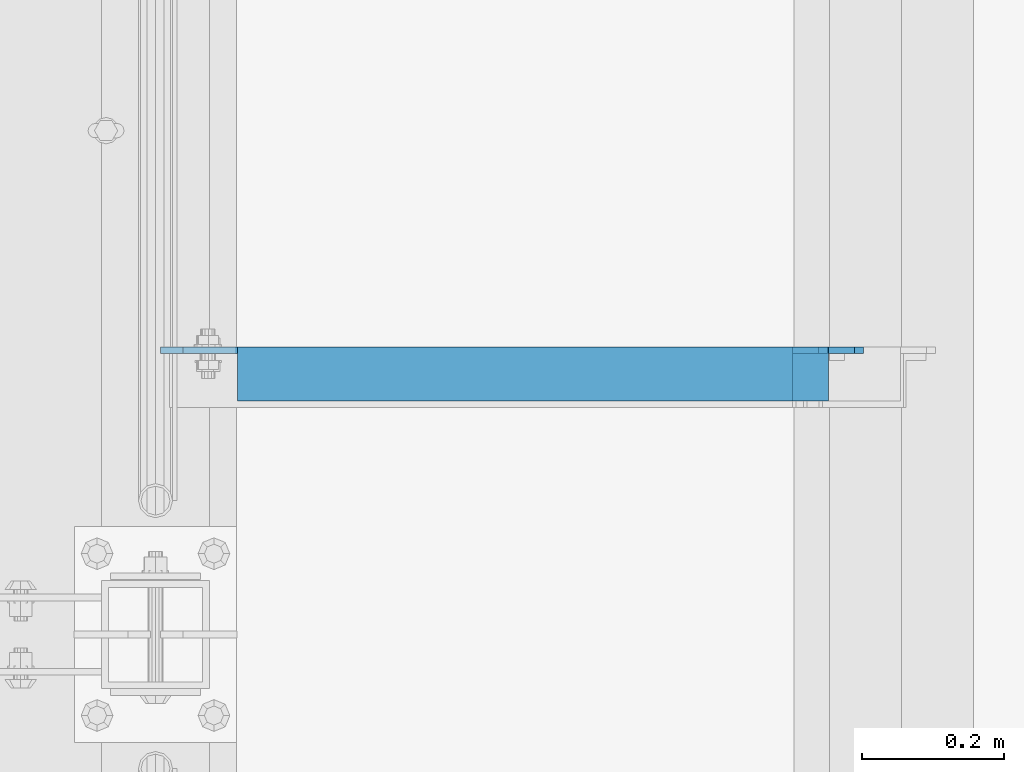
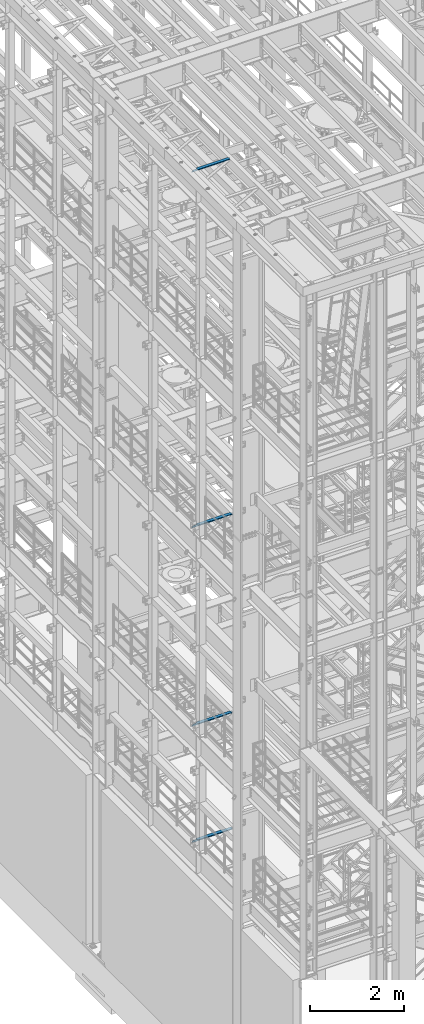
# One storey, part 1183 of 1876: 4 beams, 4 elements without a shape of their own.
"""IFC2X3 building model written with IfcOpenShell, lengths in millimetres."""

from ifc_helpers import new_model, si_unit, frame, origin_with_axes, place, context, subcontext, project, spatial, faceted_brep, material, type_object, element, aggregate, save


model = new_model("IFC2X3")

# Units and contexts
model_context = context("Model", 3, precision=1e-05, world=origin_with_axes())
body_context = subcontext(model_context, "Body", "Model", "MODEL_VIEW")
ifc_project = project(units=[si_unit("LENGTHUNIT", "METRE", prefix="MILLI"), si_unit("AREAUNIT", "SQUARE_METRE"), si_unit("VOLUMEUNIT", "CUBIC_METRE"), si_unit("MASSUNIT", "GRAM", prefix="KILO"), si_unit("TIMEUNIT", "SECOND"), si_unit("PLANEANGLEUNIT", "RADIAN"), si_unit("SOLIDANGLEUNIT", "STERADIAN"), si_unit("THERMODYNAMICTEMPERATUREUNIT", "DEGREE_CELSIUS"), si_unit("LUMINOUSINTENSITYUNIT", "LUMEN")], contexts=[model_context])

# Site, building, storey
site_placement = place(None, origin_with_axes())
site = spatial("IfcSite", under=ifc_project, at=site_placement, CompositionType="ELEMENT")
building_placement = place(site_placement, origin_with_axes())
building = spatial("IfcBuilding", under=site, at=building_placement, Name="Undefined", CompositionType="ELEMENT")
storey_placement = place(building_placement, origin_with_axes())
storey = spatial("IfcBuildingStorey", under=building, at=storey_placement, Name="Undefined", CompositionType="ELEMENT", Elevation=0.0)

# Assembly, beam
assembly_1_placement = place(storey_placement, origin_with_axes())
assembly_1 = element("IfcElementAssembly", 1, at=assembly_1_placement, inside=storey, Name="ANGLE", AssemblyPlace="NOTDEFINED", PredefinedType="RIGID_FRAME")
ifc_material = material(Name="STEEL/A36")
beam_type = type_object("IfcBeamType", Name="L3X3X3/8", PredefinedType="NOTDEFINED")
beam_1_placement = place(assembly_1_placement, frame((4.51516825708356e-09, -2171.7, 22517.1), z_axis=(0.0, -1.0, 0.0), x_axis=(1.0, 0.0, 0.0)))
beam_1 = element("IfcBeam", 2, at=beam_1_placement, type_object=beam_type, material=ifc_material, Name="ANGLE", ObjectType="L3X3X3/8", context=body_context, shape_type="Brep", body=[
    faceted_brep([(115.886999817316, 28.5750000000007, 38.0999999999999), (115.886999817316, 38.0999999999985, 38.0999999999999), (115.886998826692, 38.0999999999985, -38.0999999999999), (115.88699882669, 12.699999237062, -38.0999999999999), (115.886998950515, 12.699999237062, -28.5749999999998), (115.88699895052, 28.5750000000007, -28.5749999999998), (38.8937432114558, 12.699999237062, -38.0999999999999), (38.8937433352807, 12.699999237062, -28.5749999999998), (7.14374321145577, -19.050000762938, -38.0999999999999), (7.14374333528067, -19.050000762938, -28.5749999999998), (7.1437499954859, -38.0999999999985, -38.0999999999999), (7.1437499954859, -38.0999999999985, -28.5749999999998), (949.325002419604, 15.8750003814712, -28.5749999999998), (936.625002610339, 28.5750000000007, -28.5749999999998), (900.113000619098, 28.5750000000007, -28.5749999999998), (949.324999995485, -38.0999999999985, -28.5749999999998), (949.325002419604, 3.17500152588036, -28.5749999999998), (900.11300241932, 28.5750000000007, 38.0999999999999), (900.1130024193, 38.0999999999985, 38.0999999999999), (900.113000361957, 38.0999999999985, -38.0999999999999), (900.113000361924, 28.5750001907363, -38.0999999999999), (936.625002353164, 28.5750001907363, -38.0999999999999), (949.325002162429, 15.8750003814712, -38.0999999999999), (949.325002162429, 3.17500152588036, -38.0999999999999), (949.324999995485, -38.0999999999985, -38.0999999999999)], [[[0, 1, 2, 3, 4, 5]], [[4, 3, 6, 7]], [[7, 6, 8, 9]], [[8, 10, 11, 9]], [[12, 13, 14, 5, 4, 7, 9, 11, 15, 16]], [[0, 5, 14, 17]], [[1, 0, 17, 18]], [[2, 1, 18, 19]], [[17, 14, 20, 19, 18]], [[13, 21, 20, 14]], [[12, 22, 21, 13]], [[16, 23, 22, 12]], [[10, 8, 6, 3, 2, 19, 20, 21, 22, 23, 24]], [[11, 10, 24, 15]], [[23, 16, 15, 24]]]),
])
aggregate(assembly_1, [beam_1])

assembly_2_placement = place(storey_placement, origin_with_axes())
assembly_2 = element("IfcElementAssembly", 3, at=assembly_2_placement, inside=storey, Name="ANGLE", AssemblyPlace="NOTDEFINED", PredefinedType="RIGID_FRAME")
beam_2_placement = place(assembly_2_placement, frame((0.0, -2171.7, 8115.3), z_axis=(0.0, -1.0, 0.0), x_axis=(1.0, 0.0, 0.0)))
beam_2 = element("IfcBeam", 4, at=beam_2_placement, type_object=beam_type, material=ifc_material, Name="ANGLE", ObjectType="L3X3X3/8", context=body_context, shape_type="Brep", body=[
    faceted_brep([(115.886999817316, 28.5750000000007, 38.0999999999999), (115.886999817316, 38.0999999999985, 38.0999999999999), (115.886998826692, 38.0999999999985, -38.0999999999999), (115.88699882669, 12.699999237062, -38.0999999999999), (115.886998950515, 12.699999237062, -28.5749999999998), (115.88699895052, 28.5750000000007, -28.5749999999998), (38.8937432114558, 12.699999237062, -38.0999999999999), (38.8937433352807, 12.699999237062, -28.5749999999998), (7.14374321145577, -19.050000762938, -38.0999999999999), (7.14374333528067, -19.050000762938, -28.5749999999998), (7.1437499954859, -38.0999999999985, -38.0999999999999), (7.1437499954859, -38.0999999999985, -28.5749999999998), (1000.12500242412, 15.8750003814712, -28.5749999999998), (987.425002614851, 28.5749999999998, -28.5749999999998), (950.913000303442, 28.5749999999998, -28.5749999999998), (1000.12500001551, -38.1000000000004, -28.5749999999998), (1000.12500242412, 3.17500152588036, -28.5749999999998), (950.913001170238, 28.5749999999998, 38.0999999999999), (950.913001170238, 38.1000000000004, 38.0999999999999), (950.913000179614, 38.1000000000004, -38.0999999999999), (950.913000366403, 28.5750001907363, -38.0999999999999), (987.425002357675, 28.5750001907363, -38.0999999999999), (1000.12500216694, 15.8750003814712, -38.0999999999999), (1000.12500216694, 3.17500152588036, -38.0999999999999), (1000.12500001551, -38.1000000000004, -38.0999999999999)], [[[0, 1, 2, 3, 4, 5]], [[4, 3, 6, 7]], [[7, 6, 8, 9]], [[8, 10, 11, 9]], [[12, 13, 14, 5, 4, 7, 9, 11, 15, 16]], [[0, 5, 14, 17]], [[1, 0, 17, 18]], [[2, 1, 18, 19]], [[17, 14, 20, 19, 18]], [[13, 21, 20, 14]], [[12, 22, 21, 13]], [[16, 23, 22, 12]], [[10, 8, 6, 3, 2, 19, 20, 21, 22, 23, 24]], [[11, 10, 24, 15]], [[23, 16, 15, 24]]]),
])
aggregate(assembly_2, [beam_2])

assembly_3_placement = place(storey_placement, origin_with_axes())
assembly_3 = element("IfcElementAssembly", 5, at=assembly_3_placement, inside=storey, Name="ANGLE", AssemblyPlace="NOTDEFINED", PredefinedType="RIGID_FRAME")
beam_3_placement = place(assembly_3_placement, frame((0.0, -2171.7, 5092.7), z_axis=(0.0, -1.0, 0.0), x_axis=(1.0, 0.0, 0.0)))
beam_3 = element("IfcBeam", 6, at=beam_3_placement, type_object=beam_type, material=ifc_material, Name="ANGLE", ObjectType="L3X3X3/8", context=body_context, shape_type="Brep", body=[
    faceted_brep([(115.886999817316, 28.5750000000007, 38.0999999999999), (115.886999817316, 38.0999999999985, 38.0999999999999), (115.886998826692, 38.0999999999985, -38.0999999999999), (115.88699882669, 12.699999237062, -38.0999999999999), (115.886998950515, 12.699999237062, -28.5749999999998), (115.88699895052, 28.5750000000007, -28.5749999999998), (38.8937432114558, 12.699999237062, -38.0999999999999), (38.8937433352807, 12.699999237062, -28.5749999999998), (7.14374321145577, -19.050000762938, -38.0999999999999), (7.14374333528067, -19.050000762938, -28.5749999999998), (7.1437499954859, -38.0999999999985, -38.0999999999999), (7.1437499954859, -38.0999999999985, -28.5749999999998), (1000.12500242412, 15.8750003814712, -28.5749999999998), (987.425002614851, 28.5749999999998, -28.5749999999998), (950.913000303442, 28.5749999999998, -28.5749999999998), (1000.12500001551, -38.1000000000004, -28.5749999999998), (1000.12500242412, 3.17500152588036, -28.5749999999998), (950.913001170238, 28.5749999999998, 38.0999999999999), (950.913001170238, 38.1000000000004, 38.0999999999999), (950.913000179614, 38.1000000000004, -38.0999999999999), (950.913000366403, 28.5750001907363, -38.0999999999999), (987.425002357675, 28.5750001907363, -38.0999999999999), (1000.12500216694, 15.8750003814712, -38.0999999999999), (1000.12500216694, 3.17500152588036, -38.0999999999999), (1000.12500001551, -38.1000000000004, -38.0999999999999)], [[[0, 1, 2, 3, 4, 5]], [[4, 3, 6, 7]], [[7, 6, 8, 9]], [[8, 10, 11, 9]], [[12, 13, 14, 5, 4, 7, 9, 11, 15, 16]], [[0, 5, 14, 17]], [[1, 0, 17, 18]], [[2, 1, 18, 19]], [[17, 14, 20, 19, 18]], [[13, 21, 20, 14]], [[12, 22, 21, 13]], [[16, 23, 22, 12]], [[10, 8, 6, 3, 2, 19, 20, 21, 22, 23, 24]], [[11, 10, 24, 15]], [[23, 16, 15, 24]]]),
])
aggregate(assembly_3, [beam_3])

assembly_4_placement = place(storey_placement, origin_with_axes())
assembly_4 = element("IfcElementAssembly", 7, at=assembly_4_placement, inside=storey, Name="ANGLE", AssemblyPlace="NOTDEFINED", PredefinedType="RIGID_FRAME")
beam_4_placement = place(assembly_4_placement, frame((-1.57146639077011e-08, -2171.7, 13271.5), z_axis=(0.0, -1.0, 0.0), x_axis=(1.0, 0.0, 0.0)))
beam_4 = element("IfcBeam", 8, at=beam_4_placement, type_object=beam_type, material=ifc_material, Name="ANGLE", ObjectType="L3X3X3/8", context=body_context, shape_type="Brep", body=[
    faceted_brep([(115.886999817316, 28.5750000000007, 38.0999999999999), (115.886999817316, 38.0999999999985, 38.0999999999999), (115.886998826692, 38.0999999999985, -38.0999999999999), (115.88699882669, 12.699999237062, -38.0999999999999), (115.886998950515, 12.699999237062, -28.5749999999998), (115.88699895052, 28.5750000000007, -28.5749999999998), (38.8937432114558, 12.699999237062, -38.0999999999999), (38.8937433352807, 12.699999237062, -28.5749999999998), (7.14374321145577, -19.050000762938, -38.0999999999999), (7.14374333528067, -19.050000762938, -28.5749999999998), (7.1437499954859, -38.0999999999985, -38.0999999999999), (7.1437499954859, -38.0999999999985, -28.5749999999998), (1000.12500243948, 14.2880004882809, -28.5749999999998), (987.425002630213, 26.988000297546, -28.5749999999998), (950.913000638941, 26.988000297546, -28.5749999999998), (950.913000303442, 28.5749999999998, -28.5749999999998), (1000.12500001551, -38.1000000000004, -28.5749999999998), (1000.12500243948, 1.58799972534143, -28.5749999999998), (950.913001170238, 28.5749999999998, 38.0999999999999), (950.913001170238, 38.1000000000004, 38.0999999999999), (950.913000179614, 38.1000000000004, -38.0999999999999), (950.913000381765, 26.988000297546, -38.0999999999999), (987.425002373037, 26.988000297546, -38.0999999999999), (1000.1250021823, 14.2880004882809, -38.0999999999999), (1000.1250021823, 1.58799972534143, -38.0999999999999), (1000.12500001551, -38.1000000000004, -38.0999999999999)], [[[0, 1, 2, 3, 4, 5]], [[4, 3, 6, 7]], [[7, 6, 8, 9]], [[8, 10, 11, 9]], [[12, 13, 14, 15, 5, 4, 7, 9, 11, 16, 17]], [[0, 5, 15, 18]], [[1, 0, 18, 19]], [[2, 1, 19, 20]], [[18, 15, 14, 21, 20, 19]], [[13, 22, 21, 14]], [[12, 23, 22, 13]], [[17, 24, 23, 12]], [[10, 8, 6, 3, 2, 20, 21, 22, 23, 24, 25]], [[11, 10, 25, 16]], [[24, 17, 16, 25]]]),
])
aggregate(assembly_4, [beam_4])

save(model, "model.ifc")
